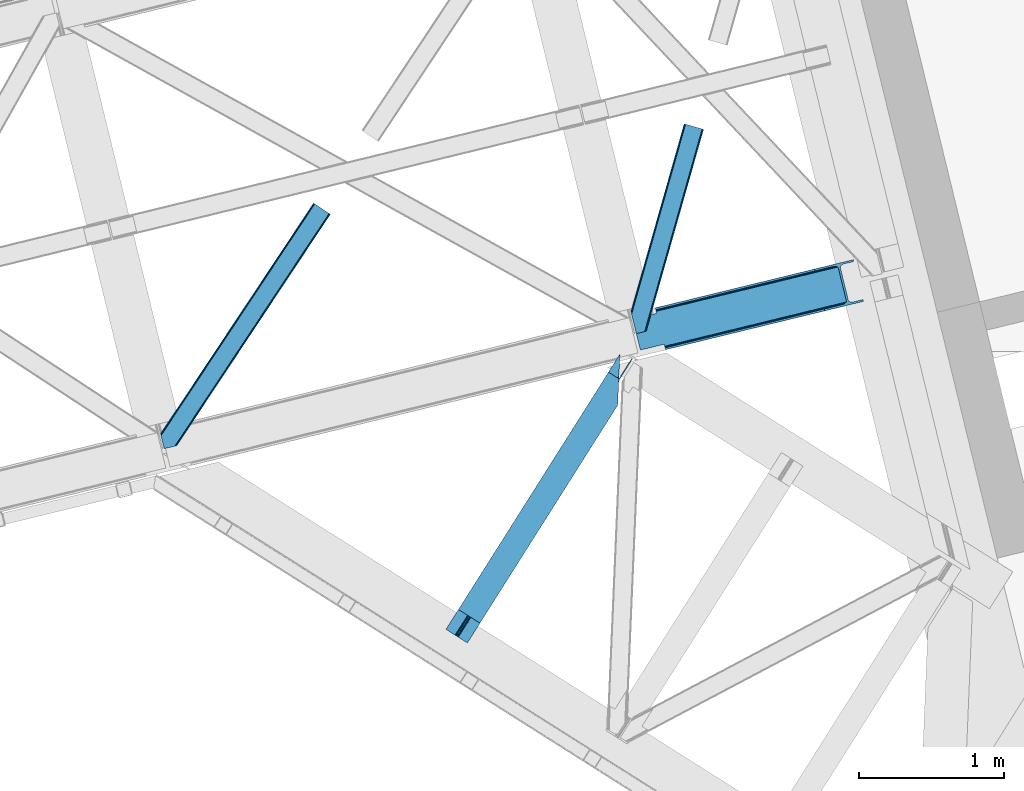
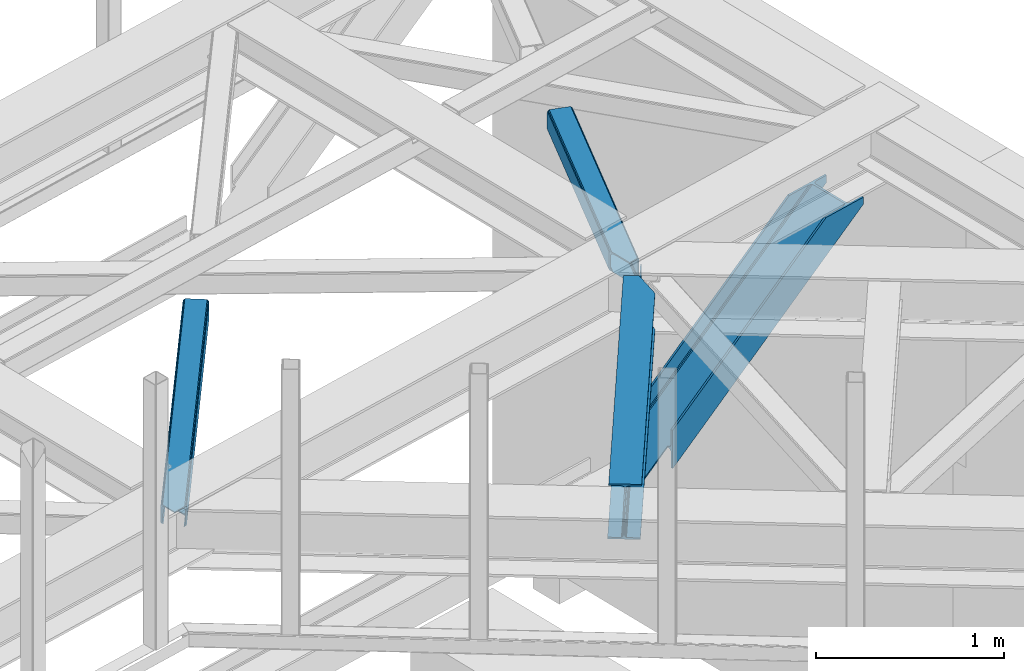
# One storey, part 58 of 66: 3 members, 1 beam.
"""IFC4 building model written with IfcOpenShell, lengths in millimetres."""

import ifcopenshell
import ifcopenshell.guid

model = None  # the IFC model being written
_history = None  # IfcOwnerHistory: only IFC2X3 demands one
_inside = {}  # id of a spatial element -> (the spatial element, [elements in it])
_under = {}  # id of a project, library or spatial element -> (it, [spatial elements below it])
_declared = {}  # id of a project -> (the project, [libraries it declares])
_typed = {}  # id of a type object -> (the type object, [elements of that type])
_made_of = {}  # id of a material, layer set ... -> (it, [elements and type objects made of it])


def new_model(schema):
    """Start an empty IFC model of exactly this schema.

    Asked for "IFC4X3", IfcOpenShell would pick the latest addendum, in which some entities
    have other attributes; the version numbers below select the first issue.
    IFC2X3 requires an IfcOwnerHistory on every rooted entity: one is made here for all.
    """
    global model, _history
    if schema == "IFC4X3":
        model = ifcopenshell.file(schema_version=(4, 3, 0, 0))
    else:
        model = ifcopenshell.file(schema=schema)
    _inside.clear()
    _under.clear()
    _declared.clear()
    _typed.clear()
    _made_of.clear()
    _history = None
    if model.schema == "IFC2X3":
        org = make("IfcOrganization", Name="unknown")
        user = make(
            "IfcPersonAndOrganization",
            ThePerson=make("IfcPerson", FamilyName="unknown"),
            TheOrganization=org,
        )
        app = make(
            "IfcApplication",
            ApplicationDeveloper=org,
            Version="unknown",
            ApplicationFullName="unknown",
            ApplicationIdentifier="unknown",
        )
        _history = make(
            "IfcOwnerHistory",
            OwningUser=user,
            OwningApplication=app,
            ChangeAction="ADDED",
            CreationDate=0,
        )
    return model


def make(cls, **values):
    """One entity of the class cls with the attributes given. An attribute that is None is left unset."""
    return model.create_entity(
        cls, **{name: value for name, value in values.items() if value is not None}
    )


def entity(cls, *values):
    """Any entity or typed value of the class cls, its attributes in the order of the schema. None: left unset."""
    e = model.create_entity(cls)
    for i, value in enumerate(values):
        if value is not None:
            e[i] = value
    return e


def rooted(cls, **values):
    """An entity with a GlobalId (a new one), such as an element, a storey or a relation."""
    return make(cls, GlobalId=ifcopenshell.guid.new(), OwnerHistory=_history, **values)


def si_unit(unit_type, name, prefix=None):
    """IfcSIUnit, for example si_unit("LENGTHUNIT", "METRE", prefix="MILLI")."""
    return make("IfcSIUnit", UnitType=unit_type, Prefix=prefix, Name=name)


def converted_unit(unit_type, name, factor, base, dimensions=None, offset=None):
    """IfcConversionBasedUnit, such as the inch: factor (a typed value) times the base unit."""
    return make(
        "IfcConversionBasedUnit"
        if offset is None
        else "IfcConversionBasedUnitWithOffset",
        ConversionOffset=offset,
        Dimensions=None
        if dimensions is None
        else entity("IfcDimensionalExponents", *dimensions),
        UnitType=unit_type,
        Name=name,
        ConversionFactor=make(
            "IfcMeasureWithUnit", ValueComponent=factor, UnitComponent=base
        ),
    )


def derived_unit(unit_type, elements):
    """IfcDerivedUnit: a product of units, each with its exponent."""
    return make(
        "IfcDerivedUnit",
        Elements=[
            make("IfcDerivedUnitElement", Unit=unit, Exponent=power)
            for unit, power in elements
        ],
        UnitType=unit_type,
    )


def assignment(units):
    """IfcUnitAssignment: the units of a project."""
    return None if units is None else make("IfcUnitAssignment", Units=units)


def point(xyz):
    """IfcCartesianPoint."""
    return None if xyz is None else make("IfcCartesianPoint", Coordinates=xyz)


def direction(xyz):
    """IfcDirection."""
    return None if xyz is None else make("IfcDirection", DirectionRatios=xyz)


def frame(location, z_axis=None, x_axis=None):
    """IfcAxis2Placement3D, a coordinate frame: its origin and axes. An axis left out is left unset."""
    return make(
        "IfcAxis2Placement3D",
        Location=point(location),
        Axis=direction(z_axis),
        RefDirection=direction(x_axis),
    )


def origin():
    """The frame at (0, 0, 0) with its axes left unset."""
    return frame((0.0, 0.0, 0.0))


def place(relative_to, where):
    """IfcLocalPlacement: puts the frame where relative to a parent placement (None: the world)."""
    return make(
        "IfcLocalPlacement", PlacementRelTo=relative_to, RelativePlacement=where
    )


def context(
    kind, dimensions, precision=None, world=None, true_north=None, identifier=None
):
    """IfcGeometricRepresentationContext, for example the 3D "Model" context."""
    return make(
        "IfcGeometricRepresentationContext",
        ContextIdentifier=identifier,
        ContextType=kind,
        CoordinateSpaceDimension=dimensions,
        Precision=precision,
        WorldCoordinateSystem=world,
        TrueNorth=true_north,
    )


def subcontext(parent, identifier, kind, view, scale=None):
    """IfcGeometricRepresentationSubContext, for example "Body" below "Model"."""
    return make(
        "IfcGeometricRepresentationSubContext",
        ContextIdentifier=identifier,
        ContextType=kind,
        ParentContext=parent,
        TargetScale=scale,
        TargetView=view,
    )


def project(units=None, contexts=None):
    """IfcProject with its units and contexts."""
    return rooted(
        "IfcProject",
        Name="project",
        RepresentationContexts=contexts,
        UnitsInContext=assignment(units),
    )


def spatial(cls, under=None, at=None, **own):
    """A site, building, storey or space (cls), placed at a placement, below another one or the project."""
    s = rooted(cls, ObjectPlacement=at, **own)
    if under is not None:
        _under.setdefault(under.id(), (under, []))[1].append(s)
    return s


def point_list(points):
    """IfcCartesianPointList2D or 3D."""
    cls = (
        "IfcCartesianPointList2D" if len(points[0]) == 2 else "IfcCartesianPointList3D"
    )
    return make(cls, CoordList=points)


def triangles(points, corners, closed=None, point_numbers=None):
    """IfcTriangulatedFaceSet: each triangle names its three corners, points numbered from 1."""
    return make(
        "IfcTriangulatedFaceSet",
        Coordinates=point_list(points),
        Closed=closed,
        CoordIndex=corners,
        PnIndex=point_numbers,
    )


def polygons(points, faces, closed=None, point_numbers=None):
    """IfcPolygonalFaceSet: a face is its outer loop, then its inner loops; points numbered from 1."""
    made = []
    for loops in faces:
        if len(loops) == 1:
            made.append(make("IfcIndexedPolygonalFace", CoordIndex=loops[0]))
        else:
            made.append(
                make(
                    "IfcIndexedPolygonalFaceWithVoids",
                    CoordIndex=loops[0],
                    InnerCoordIndices=loops[1:],
                )
            )
    return make(
        "IfcPolygonalFaceSet",
        Coordinates=point_list(points),
        Closed=closed,
        Faces=made,
        PnIndex=point_numbers,
    )


def shape(context_of_items, identifier, shape_type, items):
    """IfcShapeRepresentation: the items that make up one representation, for example the "Body"."""
    return make(
        "IfcShapeRepresentation",
        ContextOfItems=context_of_items,
        RepresentationIdentifier=identifier,
        RepresentationType=shape_type,
        Items=items,
    )


def made_of(thing, what):
    """Note that an element or type object is made of a material, layer set ...; save() writes the relation."""
    if what is not None:
        _made_of.setdefault(what.id(), (what, []))[1].append(thing)
    return thing


def type_object(cls, material=None, **own):
    """A type object (cls), such as IfcWallType, which elements share."""
    return made_of(rooted(cls, **own), material)


def element(
    cls,
    number,
    at=None,
    inside=None,
    cuts=None,
    type_object=None,
    material=None,
    context=None,
    identifier="Body",
    shape_type=None,
    held_by="IfcProductDefinitionShape",
    body=None,
    shapes=None,
    **own,
):
    """One element of the class cls, such as IfcWall. Its Tag is "e" and its number.

    at: its placement. inside: the storey or other place that contains it. cuts: it is an
    opening in that element (IfcRelVoidsElement). A single representation is given by context,
    identifier, shape_type and body (its items); several are given by shapes. held_by: the class
    of the entity that holds the representations. save() writes the other relations.
    """
    e = rooted(cls, Tag="e%d" % number, ObjectPlacement=at, **own)
    if body is not None:
        shapes = [shape(context, identifier, shape_type, body)]
    if shapes is not None:
        e.Representation = make(held_by, Representations=shapes)
    if inside is not None:
        _inside.setdefault(inside.id(), (inside, []))[1].append(e)
    if cuts is not None:
        rooted(
            "IfcRelVoidsElement", RelatingBuildingElement=cuts, RelatedOpeningElement=e
        )
    if type_object is not None:
        _typed.setdefault(type_object.id(), (type_object, []))[1].append(e)
    return made_of(e, material)


def aggregate(whole, parts):
    """IfcRelAggregates: a whole, such as a stair, and the parts it consists of."""
    return rooted("IfcRelAggregates", RelatingObject=whole, RelatedObjects=parts)


def save(model, path):
    """Write the relations noted so far, then the file.

    IfcRelAggregates (storeys below a building ...), IfcRelContainedInSpatialStructure (elements
    in a storey), IfcRelDefinesByType, IfcRelAssociatesMaterial and IfcRelDeclares: one each for
    every whole, place, type object, material and project.
    """
    for whole, parts in _under.values():
        aggregate(whole, parts)
    for where, things in _inside.values():
        rooted(
            "IfcRelContainedInSpatialStructure",
            RelatedElements=things,
            RelatingStructure=where,
        )
    for kind, things in _typed.values():
        rooted("IfcRelDefinesByType", RelatedObjects=things, RelatingType=kind)
    for what, things in _made_of.values():
        rooted("IfcRelAssociatesMaterial", RelatedObjects=things, RelatingMaterial=what)
    for by, libraries in _declared.values():
        rooted("IfcRelDeclares", RelatingContext=by, RelatedDefinitions=libraries)
    model.write(path)


model = new_model("IFC4")

# Units and contexts
model_context = context("Model", 3, precision=0.01, world=origin(), true_north=direction((6.12303176911189e-17, 1.0)))
plan_context = context("Plan", 3, precision=0.01, world=origin(), true_north=direction((6.12303176911189e-17, 1.0)))
body_context = subcontext(model_context, "Body", "Model", "MODEL_VIEW")
ifc_project = project(units=[si_unit("LENGTHUNIT", "METRE", prefix="MILLI"), si_unit("AREAUNIT", "SQUARE_METRE"), si_unit("VOLUMEUNIT", "CUBIC_METRE"), converted_unit("PLANEANGLEUNIT", "DEGREE", entity("IfcRatioMeasure", 0.0174532925199433), si_unit("PLANEANGLEUNIT", "RADIAN"), dimensions=[0, 0, 0, 0, 0, 0, 0]), si_unit("MASSUNIT", "GRAM", prefix="KILO"), derived_unit("MASSDENSITYUNIT", [(si_unit("MASSUNIT", "GRAM", prefix="KILO"), 1), (si_unit("LENGTHUNIT", "METRE"), -3)]), derived_unit("MOMENTOFINERTIAUNIT", [(si_unit("LENGTHUNIT", "METRE"), 4)]), si_unit("TIMEUNIT", "SECOND"), si_unit("FREQUENCYUNIT", "HERTZ"), si_unit("THERMODYNAMICTEMPERATUREUNIT", "DEGREE_CELSIUS"), derived_unit("THERMALTRANSMITTANCEUNIT", [(si_unit("MASSUNIT", "GRAM", prefix="KILO"), 1), (si_unit("THERMODYNAMICTEMPERATUREUNIT", "KELVIN"), -1), (si_unit("TIMEUNIT", "SECOND"), -3)]), derived_unit("VOLUMETRICFLOWRATEUNIT", [(si_unit("LENGTHUNIT", "METRE"), 3), (si_unit("TIMEUNIT", "SECOND"), -1)]), derived_unit("MASSFLOWRATEUNIT", [(si_unit("MASSUNIT", "GRAM", prefix="KILO"), 1), (si_unit("TIMEUNIT", "SECOND"), -1)]), derived_unit("ROTATIONALFREQUENCYUNIT", [(si_unit("TIMEUNIT", "SECOND"), -1)]), si_unit("ELECTRICCURRENTUNIT", "AMPERE"), si_unit("ELECTRICVOLTAGEUNIT", "VOLT"), si_unit("POWERUNIT", "WATT"), si_unit("FORCEUNIT", "NEWTON", prefix="KILO"), si_unit("ILLUMINANCEUNIT", "LUX"), si_unit("LUMINOUSFLUXUNIT", "LUMEN"), si_unit("LUMINOUSINTENSITYUNIT", "CANDELA"), derived_unit("USERDEFINED", [(si_unit("MASSUNIT", "GRAM", prefix="KILO"), -1), (si_unit("LENGTHUNIT", "METRE"), -2), (si_unit("TIMEUNIT", "SECOND"), 3), (si_unit("LUMINOUSFLUXUNIT", "LUMEN"), 1)]), derived_unit("LINEARVELOCITYUNIT", [(si_unit("LENGTHUNIT", "METRE"), 1), (si_unit("TIMEUNIT", "SECOND"), -1)]), si_unit("PRESSUREUNIT", "PASCAL"), derived_unit("USERDEFINED", [(si_unit("LENGTHUNIT", "METRE"), -2), (si_unit("MASSUNIT", "GRAM", prefix="KILO"), 1), (si_unit("TIMEUNIT", "SECOND"), -2)]), derived_unit("LINEARFORCEUNIT", [(si_unit("MASSUNIT", "GRAM", prefix="KILO"), 1), (si_unit("LENGTHUNIT", "METRE"), 1), (si_unit("TIMEUNIT", "SECOND"), -2), (si_unit("LENGTHUNIT", "METRE"), -1)]), derived_unit("PLANARFORCEUNIT", [(si_unit("MASSUNIT", "GRAM", prefix="KILO"), 1), (si_unit("LENGTHUNIT", "METRE"), 1), (si_unit("TIMEUNIT", "SECOND"), -2), (si_unit("LENGTHUNIT", "METRE"), -2)])], contexts=[model_context, plan_context])

# Site, building, storey
site_placement = place(None, origin())
site = spatial("IfcSite", under=ifc_project, at=site_placement, CompositionType="ELEMENT")
building_placement = place(site_placement, origin())
building = spatial("IfcBuilding", under=site, at=building_placement, CompositionType="ELEMENT")
storey_placement = place(building_placement, frame((0.0, 0.0, 19800.0)))
storey = spatial("IfcBuildingStorey", under=building, at=storey_placement, Name="06", CompositionType="ELEMENT", Elevation=19800.0)

# Member
member_type_1 = type_object("IfcMemberType", PredefinedType="BRACE")
member_1_placement = place(storey_placement, frame((-2187.22, 16968.36, 2617.6)))
element("IfcMember", 1, at=member_1_placement, inside=storey, type_object=member_type_1, ObjectType="Steel Vertical Brace", PredefinedType="BRACE", context=body_context, shape_type="Tessellation", body=[
    polygons([(1585.2294851225, 334.661161692477, 1042.42673521894), (1582.15074591362, 347.291338448318, 1042.42673521894), (1582.15074591362, 347.291338448318, 1088.40408877919), (1585.2294851225, 334.661161692477, 1088.40408877919), (225.056603724453, 3.10463150600978, 5.98026597646167), (221.977864515578, 15.7348082618462, 5.98026597646167), (221.977864515577, 15.7348082618462, 102.718017134371), (1515.53571242156, 331.05321926145, 1088.40408877919), (225.056603724452, 3.10463150600761, 254.823355771723), (1319.00013205867, 269.76494023208, 1088.40408877919), (217.714994841749, 33.2227453083898, 135.689726532239), (216.294038283798, 39.0520576572405, 135.689726532152), (216.294038283802, 39.0520576572405, 125.113895215846), (217.714994841748, 33.2227453083941, 125.113895215941), (219.346324440217, 26.5304015345462, 123.409110506461), (220.729298895395, 20.8569064339283, 118.554294396374), (221.653372883131, 17.0659982053532, 111.288548629352), (221.977864515572, 15.7348082618462, 254.823355771723), (221.977864515573, 15.7348082618462, 158.085604613814), (221.653372883133, 17.0659982053446, 149.515073118633), (220.729298895395, 20.856906433924, 142.249327351612), (219.346324440223, 26.5304015345462, 137.394511241533), (1451.82949340716, 592.400722901503, 1088.40408877919), (1518.44452689923, 608.638842088371, 1088.40408877919), (1515.36578769035, 621.269018844214, 1088.40408877919), (1249.13643462652, 556.372797383815, 1088.40408877919), (1252.21517383539, 543.742620627976, 1088.40408877919), (1379.16824824607, 574.688775652657, 1088.40408877919), (1390.74021368898, 576.099276446501, 1088.40408877919), (1401.19943555815, 574.632661393906, 1088.40408877918), (1408.95359213711, 570.512209341736, 1088.40408877919), (1412.8221833783, 564.365221762941, 1088.40408877919), (1468.00266304505, 337.993592215981, 1088.40408877919), (1467.39673100087, 330.755892246851, 1088.40408877919), (1462.40852333225, 323.529354097781, 1088.40408877919), (1453.79744943855, 317.414152693241, 1088.40408877919), (1442.87446726047, 313.341272012599, 1088.40408877919), (1315.92139284979, 282.395116987918, 1088.40408877918), (1503.96374697866, 329.64271846761, 1088.40408877919), (1493.50452510946, 331.109333520199, 1088.40408877918), (1485.7503685305, 335.229785572367, 1088.40408877918), (1481.8817772893, 341.376773151153, 1088.40408877919), (1426.70129762255, 567.748402698115, 1088.40408877919), (1427.30722966674, 574.986102667243, 1088.40408877919), (1432.29543733536, 582.212640816317, 1088.40408877919), (1440.90651122909, 588.327842220875, 1088.40408877919), (3.24860138789518e-12, 212.769900732995, 1.8192167772213e-10), (163.220745767809, 252.556684355379, 124.373576309325), (163.955471732924, 253.765062506503, 125.113895215868), (162.534515175014, 259.594374855358, 125.113895215928), (215.085660132705, 39.7867836223989, 124.373576309312), (51.8649143648549, 4.33146851719357e-12, 6.49720277579036e-11), (162.534515175012, 259.594374855358, 135.689726532226), (163.95547173292, 253.765062506501, 135.68972653217), (163.220745767806, 252.556684355379, 134.949407625623), (2.8966695708732e-11, 212.769900732999, 10.5758313165188), (51.8649143648817, 1.08286712929839e-11, 10.5758313164365), (215.085660132696, 39.7867836223968, 134.949407625615), (160.903185576499, 266.286718629312, 137.394511241728), (159.520211121322, 271.960213729928, 142.249327351807), (158.596137133586, 275.751121958501, 149.515073118828), (158.271645501173, 277.082311901899, 158.085604613814), (158.271645501172, 277.082311901899, 254.823355771723), (155.192906292298, 289.712488657742, 254.823355771723), (155.192906292296, 289.712488657742, 5.98026597646167), (158.271645501172, 277.082311901899, 5.98026597646167), (158.271645501173, 277.082311901904, 102.718017134371), (158.59613713359, 275.751121958499, 111.28854862956), (159.520211121322, 271.960213729926, 118.554294396582), (160.903185576492, 266.28671862931, 123.409110506656), (1518.44452689923, 608.638842088371, 1042.42673521895), (1515.36578769035, 621.269018844214, 1042.42673521894)], [[[1, 2, 3, 4]], [[5, 6, 2, 1]], [[6, 7, 8, 3, 2]], [[9, 5, 1, 4, 10]], [[11, 12, 13, 14, 15, 16, 17, 7, 6, 5, 9, 18, 19, 20, 21, 22]], [[23, 24, 25, 26, 27, 28, 29, 30, 31, 32, 33, 34, 35, 36, 37, 38, 10, 4, 3, 8, 39, 40, 41, 42, 43, 44, 45, 46]], [[42, 41, 15, 14]], [[41, 40, 16, 15]], [[40, 39, 17, 16]], [[39, 8, 7, 17]], [[18, 9, 10, 38]], [[19, 18, 38, 37]], [[37, 36, 20, 19]], [[36, 35, 21, 20]], [[35, 34, 22, 21]], [[34, 33, 11, 22]], [[47, 48, 49, 50, 43, 42, 14, 13, 51, 52]], [[53, 54, 55, 56, 57, 58, 12, 11, 33, 32]], [[58, 57, 52, 51]], [[57, 56, 47, 52]], [[56, 55, 48, 47]], [[54, 53, 59, 60, 61, 62, 63, 64, 65, 66, 67, 68, 69, 70, 50, 49]], [[23, 46, 68, 67]], [[46, 45, 69, 68]], [[45, 44, 70, 69]], [[44, 43, 50, 70]], [[67, 66, 71, 24, 23]], [[72, 25, 24, 71]], [[66, 65, 72, 71]], [[65, 64, 26, 25, 72]], [[32, 31, 59, 53]], [[31, 30, 60, 59]], [[30, 29, 61, 60]], [[29, 28, 62, 61]], [[63, 62, 28, 27]], [[64, 63, 27, 26]]], closed=False),
])

# Beam
beam_type = type_object("IfcBeamType", PredefinedType="BEAM")
beam_placement = place(storey_placement, frame((-3471.98, 14954.96, 3864.0)))
element("IfcBeam", 2, at=beam_placement, inside=storey, type_object=beam_type, ObjectType="Steel Beam", PredefinedType="BEAM", context=body_context, shape_type="Tessellation", body=[
    triangles([(1188.72613334656, 1816.41354675293, 230.999853515623), (1188.08329467773, 1793.75679016113, 228.313970947263), (1188.92815589905, 1796.73218994141, 227.025677490234), (1187.41618423462, 1786.02702941895, 230.999853515623), (1190.21528663635, 1815.46941833496, 227.193109130858), (1191.30315628052, 1805.13516540527, 223.384039306638), (1194.96863021851, 1812.46611328125, 221.005114746094), (1191.70894546509, 1814.52645263672, 223.384039306638), (1191.71897392273, 1805.96185913086, 223.116613769529), (163.219397735596, 181.395904541016, 217.00070800781), (1194.53856925964, 1812.73818969727, 217.00070800781), (164.249276733398, 180.744781494141, 223.123590087889), (167.180783843994, 178.891406250001, 228.313970947263), (1187.27709388733, 1782.76792602539, 231.783526611329), (1186.75067253113, 1770.47332763672, 232.99973144531), (171.567144012451, 176.117156982422, 231.783526611329), (176.744734954834, 172.846426391601, 232.99973144531), (1180.87254295349, 1633.92584838867, 232.99973144531), (234.219715118408, 136.50910949707, 232.99973144531), (1188.72613334656, 1816.41354675293, 244.001385498046), (1180.87254295349, 1633.92584838867, 244.001385498046), (234.219715118408, 136.50910949707, 244.001385498046), (1117.61957244873, 1861.36429138184, 244.001385498046), (86.3005462646483, 230.022006225587, 244.001385498046), (1117.61957244873, 1861.36429138184, 232.99973144531), (86.3005462646483, 230.022006225587, 232.99973144531), (1175.09905815125, 1825.02813720703, 232.99973144531), (143.779886627197, 193.685852050781, 232.99973144531), (1187.59422569275, 1817.12978210449, 223.123590087889), (1188.62410469055, 1816.47865905762, 217.00070800781), (157.300572967529, 185.135211181641, 217.00070800781), (156.270693969726, 185.786334228516, 223.123590087889), (1184.66271858215, 1818.98315734863, 228.313970947263), (153.339186859131, 187.639709472656, 228.313970947263), (1180.27214355469, 1821.75624389649, 231.783526611329), (148.953117370605, 190.413958740235, 231.783526611329), (1188.62410469055, 1816.47865905762, 204.001501464842), (1194.53856925964, 1812.73818969727, 204.001501464842), (163.219397735596, 181.395904541016, 204.001501464842), (157.300572967529, 185.135211181641, 204.001501464842), (1284.44601745605, 1954.95276489258, 202.999237060547), (1278.52704734802, 1958.6920715332, 202.999237060547), (1195.07443771362, 1813.58348693848, 202.999237060547), (1189.15546760559, 1817.32395629883, 202.999237060547), (1284.44601745605, 1954.95276489258, 119.99965209961), (1278.52704734802, 1958.6920715332, 119.99965209961), (162.88715057373, 180.872680664063, 203.057373046875), (156.76921005249, 184.291076660156, 202.999237060547), (76.9188514709472, 44.8867950439453, 202.999237060547), (71.0000267028809, 48.626101684571, 202.999237060547), (1200.5501209259, 1835.34494934082, 119.99965209961), (1199.94579734802, 1821.28883056641, 119.99965209961), (1196.02728652954, 1828.19306030274, 119.162493896485), (1195.42281761169, 1814.13694152832, 119.162493896485), (1192.19612503052, 1822.13180236816, 116.778918457032), (1191.59180145264, 1808.07568359375, 116.778918457032), (1189.63639755249, 1818.08088684082, 113.209368896485), (1189.03192863464, 1804.02476806641, 113.209368896485), (1188.73383636475, 1816.65771789551, 109.000323486329), (1188.12951278687, 1802.6015991211, 109.000323486329), (1188.95184631348, 1817.00072021484, 203.075976562501), (1188.73383636475, 1816.65771789551, 27.0006774902322), (71.0000267028809, 48.626101684571, 27.0006774902322), (1189.59076080322, 1836.49139099121, 12.2178588867173), (1190.11718215942, 1848.78598937988, 10.9993286132813), (57.4793403625486, 57.1779052734382, 10.9993286132813), (62.6525711059571, 53.9048492431648, 12.2178588867173), (1189.13977088928, 1826.06760864258, 15.6874145507791), (67.0432914733888, 51.1317626953132, 15.6874145507791), (1188.84124259949, 1819.10291748047, 20.877795410157), (69.9747985839845, 49.2783874511715, 20.877795410157), (1195.99080619812, 1985.3323059082, 10.9993286132813), (0.0, 93.5140594482418, 10.9993286132813), (1195.99080619812, 1985.3323059082, 0.0), (0.0, 93.5140594482418, 0.0), (1180.87254295349, 1633.92584838867, 0.0), (147.91916885376, 0.0, 0.0), (85.2665977478027, 39.6080474853516, 12.2178588867173), (80.8802375793457, 42.3822967529304, 15.6874145507791), (76.9188514709472, 44.8867950439453, 27.0006774902322), (77.94873046875, 44.2356719970703, 20.877795410157), (90.4441886901855, 36.3373168945309, 10.9993286132813), (147.91916885376, 0.0, 10.9993286132813), (1187.27709388733, 1782.76792602539, 12.2178588867173), (1186.75067253113, 1770.47332763672, 10.9993286132813), (1188.02661209106, 1800.15639953613, 20.877795410157), (1187.7279384613, 1793.19170837402, 15.6874145507791), (1188.12951278687, 1802.6015991211, 27.0006774902322), (1180.87254295349, 1633.92584838867, 10.9993286132813)], [[1, 2, 3], [1, 4, 2], [5, 3, 6], [7, 8, 9], [6, 9, 8], [6, 8, 5], [3, 5, 1], [10, 11, 9], [11, 7, 9], [12, 9, 6], [6, 13, 12], [6, 3, 13], [2, 13, 3], [13, 4, 14], [13, 2, 4], [14, 15, 16], [17, 16, 15], [14, 16, 13], [9, 12, 10], [15, 18, 17], [19, 17, 18], [20, 14, 4], [14, 20, 15], [4, 1, 20], [21, 15, 20], [21, 18, 15], [18, 21, 22], [22, 19, 18], [21, 23, 24], [23, 21, 20], [24, 22, 21], [23, 25, 24], [26, 24, 25], [25, 27, 28], [28, 26, 25], [29, 30, 31], [31, 32, 29], [33, 29, 32], [32, 34, 33], [35, 33, 36], [34, 36, 33], [27, 35, 36], [36, 28, 27], [1, 35, 20], [8, 7, 11], [30, 11, 37], [37, 11, 38], [8, 29, 5], [11, 30, 8], [5, 33, 1], [27, 20, 35], [33, 5, 29], [30, 29, 8], [33, 35, 1], [27, 23, 20], [23, 27, 25], [13, 16, 36], [17, 22, 24], [19, 22, 17], [16, 17, 28], [10, 12, 32], [12, 13, 32], [39, 10, 40], [34, 13, 36], [24, 28, 17], [28, 36, 16], [24, 26, 28], [32, 31, 10], [31, 40, 10], [34, 32, 13], [41, 42, 43], [44, 43, 42], [41, 45, 42], [46, 42, 45], [47, 48, 49], [50, 49, 48], [46, 45, 51], [52, 51, 45], [51, 52, 53], [54, 53, 52], [53, 54, 55], [56, 55, 54], [57, 55, 56], [56, 58, 57], [59, 57, 58], [58, 60, 59], [57, 37, 61], [57, 61, 55], [53, 55, 61], [42, 46, 51], [51, 61, 42], [61, 51, 53], [62, 48, 59], [59, 48, 31], [63, 48, 62], [63, 50, 48], [31, 37, 59], [59, 37, 57], [31, 30, 37], [64, 65, 66], [66, 67, 64], [68, 64, 67], [67, 69, 68], [70, 68, 69], [69, 71, 70], [62, 70, 71], [71, 63, 62], [65, 72, 73], [73, 66, 65], [72, 74, 75], [75, 73, 72], [74, 76, 75], [77, 75, 76], [78, 79, 67], [80, 71, 81], [79, 81, 69], [80, 49, 63], [82, 75, 77], [77, 83, 82], [82, 78, 66], [67, 79, 69], [71, 80, 63], [50, 63, 49], [71, 69, 81], [75, 82, 66], [67, 66, 78], [73, 75, 66], [68, 64, 84], [65, 74, 76], [72, 74, 65], [64, 65, 85], [62, 70, 86], [70, 68, 87], [59, 62, 88], [87, 68, 84], [76, 85, 65], [85, 84, 64], [76, 89, 85], [86, 88, 62], [88, 60, 59], [87, 86, 70], [86, 88, 80], [80, 81, 86], [87, 86, 81], [81, 79, 87], [84, 87, 79], [79, 78, 84], [85, 84, 78], [78, 82, 85], [89, 85, 82], [82, 83, 89], [76, 89, 77], [83, 77, 89]]),
])

# Members
member_type_2 = type_object("IfcMemberType", PredefinedType="BRACE")
member_2_placement = place(storey_placement, frame((-5433.35, 16290.3, 3823.02)))
element("IfcMember", 3, at=member_2_placement, inside=storey, type_object=member_type_2, ObjectType="Steel Horizontal Brace", PredefinedType="BRACE", context=body_context, shape_type="Tessellation", body=[
    triangles([(1167.55605926514, 1611.29350891113, 17.4989318847656), (1167.55605926514, 1611.29350891113, 122.499499511716), (112.764628601074, 21.275445556641, 17.4989318847656), (112.764628601074, 21.275445556641, 122.499499511716), (1166.44769668579, 1612.03067321777, 129.196765136716), (110.858349609375, 20.810357666016, 129.196765136716), (1163.28451766968, 1614.12705688477, 134.873162841795), (105.426704406738, 19.486019897462, 134.873162841795), (1158.55573654175, 1617.26640014649, 138.668280029295), (97.3022003173828, 17.5059082031257, 138.668280029295), (1152.97613525391, 1620.96849975586, 139.998431396481), (87.713832092285, 15.1688415527351, 139.998431396481), (5.64326019287091, 81.3950317382823, 139.998431396481), (1065.47537155151, 1679.01263122559, 139.998431396481), (25.4839096069336, 0.0, 139.998431396481), (1059.89577026367, 1682.71473083496, 138.668280029295), (3.48350830078107, 90.2537933349613, 138.668280029295), (1055.16698913574, 1685.85407409668, 134.873162841795), (1.65280609130878, 97.7649627685551, 134.873162841795), (1052.00381011963, 1687.95045776367, 129.196765136716), (0.42962493896448, 102.7832611084, 129.196765136716), (1050.89573822022, 1688.68762207031, 122.499499511716), (0.0, 104.544781494142, 122.499499511716), (1050.89573822022, 1688.68762207031, 17.4989318847656), (0.0, 104.544781494142, 17.4989318847656), (1166.44769668579, 1612.03067321777, 10.8016662597656), (1163.28451766968, 1614.12705688477, 5.12526855468604), (159.822802734375, 95.9557708740231, 9.25757446288844), (160.257078552246, 97.3742889404293, 8.49948120117188), (159.407711791992, 100.858959960939, 5.12526855468604), (110.469419860839, 20.7150146484382, 10.8691040039048), (109.995030212403, 20.5999053955074, 9.49942016601563), (1152.97613525391, 1620.96849975586, 0.0), (1158.55573654175, 1617.26640014649, 1.33247680663771), (155.417839050293, 117.227728271484, 0.0), (157.577009582519, 108.368966674805, 1.33247680663771), (1065.47537155151, 1679.01263122559, 0.0), (121.558859252929, 256.129714965822, 0.0), (155.314356994629, 113.429122924807, 9.49942016601563), (90.5967956542972, 15.8711242675781, 9.49942016601563), (155.425978088379, 114.267443847655, 9.2947814941399), (155.539343261718, 115.1185546875, 9.08781738280959), (160.118714904786, 96.9219909667972, 8.74132690429542), (155.650964355469, 115.956875610353, 8.8831787109375), (155.446325683593, 117.1102935791, 8.49948120117188), (1152.72004623413, 1621.13593139648, 8.33204956054396), (1147.14073562622, 1624.83803100586, 6.99957275390625), (153.160418701172, 126.488790893554, 6.99957275390625), (1157.45347824097, 1617.99775085449, 12.1248413085923), (95.4092926025387, 17.0443084716808, 12.1248413085923), (1161.72501983643, 1615.16420288086, 24.4985046386719), (1160.61200637817, 1615.90020446777, 17.8035644531228), (102.742565917969, 18.8325714111324, 24.4985046386719), (100.835705566406, 18.3674835205074, 17.8035644531228), (1161.72501983643, 1615.16420288086, 115.49992675781), (102.742565917969, 18.8325714111324, 115.49992675781), (100.835705566406, 18.3674835205074, 122.19719238281), (87.2801376342777, 15.0630340576172, 131.666381835938), (77.6917694091799, 12.7259674072266, 132.998858642575), (25.4839096069336, 0.0, 132.998858642575), (95.4092926025387, 17.0443084716808, 127.873590087889), (1147.14073562622, 1624.83803100586, 132.998858642575), (1152.72004623413, 1621.13593139648, 131.666381835938), (1157.45347824097, 1617.99775085449, 127.873590087889), (1160.61200637817, 1615.90020446777, 122.19719238281), (7.90068054199219, 72.1351318359375, 132.998858642575), (1071.3107711792, 1675.14309997558, 132.998858642575), (1056.72648696899, 1684.81692810058, 115.49992675781), (1057.83950042725, 1684.0820892334, 122.19719238281), (2.25742034912128, 95.2848815917987, 115.49992675781), (2.68704528808576, 93.5233612060547, 122.19719238281), (1060.99802856445, 1681.98338012695, 127.873590087889), (3.91022644043005, 88.505062866212, 127.873590087889), (1065.73146057129, 1678.84636230469, 131.666381835938), (5.74092864990234, 80.9938934326183, 131.666381835938), (1060.99802856445, 1681.98338012695, 12.1248413085923), (1059.89577026367, 1682.71473083496, 1.33247680663771), (1055.16698913574, 1685.85407409668, 5.12526855468604), (1071.3107711792, 1675.14309997558, 6.99957275390625), (1065.73146057129, 1678.84636230469, 8.33204956054396), (1056.72648696899, 1684.81692810058, 24.4985046386719), (1052.00381011963, 1687.95045776367, 10.8016662597656), (1057.83950042725, 1684.0820892334, 17.8035644531228), (2.25742034912128, 95.2848815917987, 24.4985046386719), (123.816279602051, 246.869815063475, 6.99957275390625), (2.88121948242224, 92.7245727539066, 16.4989929199219), (2.77483062744159, 93.1629180908203, 17.868676757811), (0.0093017578128638, 104.50757446289, 16.4989929199219), (119.399688720703, 264.988476562501, 1.33247680663771), (121.662922668457, 255.702996826172, 8.41343994140334), (117.568986511231, 272.499645996095, 5.12526855468604), (116.719619750977, 275.983154296877, 8.49948120117188), (4.73924560546857, 108.865447998049, 10.8714294433594), (115.787118530274, 275.584341430664, 9.49942016601563), (5.89266357421911, 109.927011108399, 9.49942016601563), (7.20479278564471, 93.4687133789066, 12.1248413085923), (120.157200622559, 257.658691406252, 9.49942016601563), (121.184463500977, 256.801766967774, 8.80643920898365), (10.2621643066404, 92.0013610839851, 9.49942016601563)], [[1, 2, 3], [4, 3, 2], [2, 5, 4], [6, 4, 5], [5, 7, 6], [8, 6, 7], [7, 9, 8], [10, 8, 9], [9, 11, 10], [12, 10, 11], [11, 13, 12], [11, 14, 13], [13, 15, 12], [14, 16, 17], [17, 13, 14], [16, 18, 19], [19, 17, 16], [18, 20, 21], [21, 19, 18], [20, 22, 23], [23, 21, 20], [22, 24, 23], [25, 23, 24], [26, 1, 3], [27, 28, 29], [29, 30, 27], [26, 31, 28], [28, 27, 26], [31, 32, 28], [33, 34, 35], [36, 35, 34], [34, 27, 36], [30, 36, 27], [3, 31, 26], [37, 33, 38], [35, 38, 33], [39, 28, 32], [32, 40, 39], [39, 41, 28], [41, 42, 43], [42, 44, 43], [44, 45, 29], [46, 47, 48], [49, 46, 45], [45, 44, 49], [49, 42, 41], [42, 49, 44], [41, 39, 49], [49, 39, 50], [40, 50, 39], [48, 45, 46], [51, 52, 53], [54, 53, 52], [52, 49, 54], [50, 54, 49], [55, 51, 53], [53, 56, 55], [57, 4, 6], [58, 10, 12], [15, 59, 12], [59, 15, 60], [59, 58, 12], [61, 10, 58], [61, 57, 8], [8, 10, 61], [6, 8, 57], [53, 3, 4], [50, 32, 54], [57, 56, 4], [50, 40, 32], [53, 54, 3], [56, 53, 4], [31, 3, 54], [54, 32, 31], [62, 63, 58], [58, 59, 62], [63, 64, 61], [61, 58, 63], [64, 65, 57], [57, 61, 64], [65, 55, 56], [56, 57, 65], [62, 66, 67], [66, 62, 59], [60, 66, 59], [68, 69, 70], [71, 70, 69], [69, 72, 71], [73, 71, 72], [72, 74, 73], [75, 73, 74], [74, 67, 75], [66, 75, 67], [26, 49, 52], [51, 2, 1], [26, 52, 1], [26, 27, 49], [52, 51, 1], [49, 27, 34], [47, 33, 37], [33, 46, 34], [46, 33, 47], [46, 49, 34], [5, 64, 7], [55, 2, 51], [2, 65, 5], [65, 2, 55], [5, 65, 64], [11, 62, 14], [9, 7, 64], [64, 63, 9], [63, 62, 11], [11, 9, 63], [76, 77, 78], [37, 79, 47], [37, 80, 79], [80, 37, 77], [76, 80, 77], [81, 24, 22], [82, 83, 76], [78, 82, 76], [83, 82, 24], [81, 83, 24], [16, 72, 18], [14, 62, 67], [67, 74, 14], [74, 72, 16], [16, 14, 74], [20, 18, 72], [22, 68, 81], [69, 22, 20], [22, 69, 68], [69, 20, 72], [81, 68, 84], [70, 84, 68], [47, 79, 85], [85, 48, 47], [75, 66, 13], [66, 15, 13], [66, 60, 15], [17, 75, 13], [73, 17, 19], [73, 75, 17], [86, 87, 88], [23, 70, 71], [71, 19, 21], [19, 71, 73], [21, 23, 71], [23, 84, 70], [25, 88, 87], [25, 84, 23], [84, 25, 87], [85, 38, 48], [89, 90, 91], [90, 89, 38], [91, 90, 92], [38, 85, 90], [48, 38, 35], [36, 45, 35], [45, 36, 30], [35, 45, 48], [30, 29, 45], [24, 82, 93], [93, 25, 24], [94, 93, 82], [94, 95, 93], [78, 91, 92], [92, 82, 78], [92, 94, 82], [78, 77, 91], [89, 91, 77], [77, 37, 89], [38, 89, 37], [93, 88, 25], [83, 81, 84], [83, 86, 96], [83, 87, 86], [80, 97, 98], [76, 96, 97], [97, 80, 76], [96, 99, 97], [79, 80, 90], [90, 85, 79], [96, 76, 83], [84, 87, 83], [95, 96, 93], [95, 99, 96], [96, 88, 93], [86, 88, 96], [94, 97, 95], [99, 95, 97]]),
])
member_type_3 = type_object("IfcMemberType", PredefinedType="BRACE")
member_3_placement = place(storey_placement, frame((-2200.6, 17081.3, 3823.02)))
element("IfcMember", 4, at=member_3_placement, inside=storey, type_object=member_type_3, ObjectType="Steel Horizontal Brace", PredefinedType="BRACE", context=body_context, shape_type="Tessellation", body=[
    triangles([(382.458631896973, 1437.45993347168, 139.998431396481), (376.014548492432, 1439.28889160157, 138.668280029295), (5.18718338012695, 133.445343017578, 138.668280029295), (8.40283012390137, 120.253125000003, 139.998431396481), (370.552672576904, 1440.83879699707, 134.873162841795), (2.46118698120108, 144.628381347658, 134.873162841795), (366.905947494507, 1441.87594299317, 129.196765136716), (0.639641189575286, 152.101181030273, 129.196765136716), (365.625211715698, 1442.23987426758, 122.499499511716), (0.0, 154.725439453126, 122.499499511716), (365.625211715698, 1442.23987426758, 17.4989318847656), (0.0, 154.725439453126, 17.4989318847656), (86.8012424468993, 11.9643859863281, 139.998431396481), (483.46365852356, 1408.77563781738, 139.998431396481), (37.7160118103025, 0.0, 139.998431396481), (500.297078704834, 1403.99453430176, 122.499499511716), (499.016342926025, 1404.35846557617, 129.196765136716), (106.348595809936, 16.7292114257834, 122.499499511716), (104.86191329956, 16.3664428710945, 129.196765136716), (495.369617843628, 1405.39561157227, 134.873162841795), (100.623509216308, 15.3339477539084, 134.873162841795), (489.9077419281, 1406.9466796875, 138.668280029295), (94.2839252471922, 13.7886932373076, 138.668280029295), (500.297078704834, 1403.99453430176, 17.4989318847656), (106.348595809936, 16.7292114257834, 17.4989318847656), (370.552672576904, 1440.83879699707, 5.12526855468604), (376.014548492432, 1439.28889160157, 1.33247680663771), (64.4095859527588, 341.997729492188, 1.33247680663771), (366.905947494507, 1441.87594299317, 10.8016662597656), (57.6633407592772, 340.35364379883, 5.49966430664063), (1.58013610839816, 155.411444091798, 10.8016662597656), (0.350269317626953, 153.288317871094, 12.4992370605469), (6.16328659057626, 158.997271728516, 5.49966430664063), (382.458631896973, 1437.45993347168, 0.0), (71.8924140930176, 343.822036743164, 0.0), (101.030170440674, 15.4327789306662, 5.49966430664063), (149.676183700562, 186.73860168457, 5.49966430664063), (44.5164688110349, 1.65687561035156, 5.49966430664063), (109.170516586304, 352.90869140625, 5.49966430664063), (149.709902572632, 188.722201538087, 4.99969482421875), (489.9077419281, 1406.9466796875, 1.33247680663771), (495.369617843628, 1405.39561157227, 5.12526855468604), (149.739115905762, 190.703475952148, 4.49972534179688), (149.724436569214, 189.72214050293, 4.74622192382594), (147.329379272461, 200.588919067384, 1.33247680663771), (499.016342926025, 1404.35846557617, 10.8016662597656), (104.86191329956, 16.3664428710945, 10.8016662597656), (149.690717697144, 187.719937133792, 5.25084228515334), (483.46365852356, 1408.77563781738, 0.0), (144.113877868652, 213.779974365236, 0.0), (110.142114257812, 353.145886230472, 0.0), (109.541133499145, 352.999383544924, 5.42292480468677), (110.142114257812, 353.145886230472, 4.49972534179688), (43.0614704132081, 1.30224609375, 6.99957275390625), (14.8120319366453, 117.192846679689, 6.99957275390625), (10.8560234069823, 127.785223388673, 8.33204956054396), (5.64776573181143, 131.555923461914, 12.4992370605469), (377.289616012573, 1438.92844848633, 12.1248413085923), (373.638385391235, 1439.96326904297, 17.8035644531228), (4.00077323913547, 138.312487792969, 17.8035644531228), (389.191069793701, 1435.54725952149, 6.99957275390625), (382.751637268066, 1437.37738037109, 8.33204956054396), (372.357649612427, 1440.32720031738, 24.4985046386719), (3.36113204956064, 140.936746215823, 24.4985046386719), (78.9841323852538, 10.0586883544929, 6.99957275390625), (476.731220626831, 1410.68831176758, 6.99957275390625), (372.357649612427, 1440.32720031738, 115.49992675781), (3.36113204956064, 140.936746215823, 115.49992675781), (5.82231903076172, 130.839688110354, 127.873590087889), (4.00077323913547, 138.312487792969, 122.19719238281), (8.54831542968759, 119.656649780274, 131.666381835938), (11.763962173462, 106.464431762695, 132.998858642575), (37.7160118103025, 0.0, 132.998858642575), (373.638385391235, 1439.96326904297, 122.19719238281), (377.289616012573, 1438.92844848633, 127.873590087889), (382.751637268066, 1437.37738037109, 131.666381835938), (389.191069793701, 1435.54725952149, 132.998858642575), (78.9841323852538, 10.0586883544929, 132.998858642575), (476.731220626831, 1410.68831176758, 132.998858642575), (488.632529067993, 1407.30712280274, 12.1248413085923), (492.283905029297, 1406.27113952637, 17.8035644531228), (493.564640808105, 1405.90720825196, 24.4985046386719), (483.175158691406, 1408.8593536377, 8.33204956054396), (488.632529067993, 1407.30712280274, 127.873590087889), (493.564640808105, 1405.90720825196, 115.49992675781), (492.283905029297, 1406.27113952637, 122.19719238281), (483.175158691406, 1408.8593536377, 131.666381835938), (86.4623096466062, 11.8818328857451, 131.666381835938), (92.8063991546628, 13.4282501220732, 127.873590087889), (97.0402976989744, 14.4607452392593, 122.19719238281), (98.5314857482908, 14.8235137939482, 115.49992675781), (86.4623096466062, 11.8818328857451, 8.33204956054396), (97.0402976989744, 14.4607452392593, 17.8035644531228), (92.8063991546628, 13.4282501220732, 12.1248413085923), (98.5314857482908, 14.8235137939482, 24.4985046386719)], [[1, 2, 3], [3, 4, 1], [2, 5, 6], [6, 3, 2], [5, 7, 8], [8, 6, 5], [7, 9, 10], [10, 8, 7], [9, 11, 12], [12, 10, 9], [4, 13, 14], [13, 4, 15], [14, 1, 4], [16, 17, 18], [19, 18, 17], [17, 20, 19], [21, 19, 20], [20, 22, 21], [23, 21, 22], [22, 14, 23], [13, 23, 14], [24, 16, 25], [18, 25, 16], [26, 27, 28], [29, 26, 30], [11, 29, 31], [31, 12, 11], [31, 32, 12], [29, 30, 31], [33, 31, 30], [28, 30, 26], [27, 34, 35], [35, 28, 27], [36, 33, 37], [36, 38, 33], [30, 37, 33], [39, 37, 30], [40, 41, 42], [43, 41, 44], [40, 44, 41], [43, 45, 41], [46, 47, 37], [37, 42, 46], [37, 48, 42], [47, 36, 37], [46, 24, 25], [25, 47, 46], [49, 41, 50], [45, 50, 41], [51, 35, 34], [50, 51, 49], [34, 49, 51], [35, 30, 28], [35, 51, 52], [35, 52, 30], [52, 51, 53], [48, 37, 39], [44, 40, 53], [43, 44, 53], [53, 50, 43], [50, 53, 51], [45, 43, 50], [38, 54, 55], [33, 55, 56], [55, 33, 38], [57, 31, 33], [33, 56, 57], [32, 31, 57], [58, 59, 60], [60, 57, 58], [61, 62, 56], [56, 55, 61], [62, 58, 57], [57, 56, 62], [59, 63, 64], [64, 60, 59], [55, 65, 66], [65, 55, 54], [66, 61, 55], [63, 67, 64], [68, 64, 67], [69, 6, 70], [71, 72, 4], [72, 15, 4], [72, 73, 15], [3, 71, 4], [69, 3, 6], [69, 71, 3], [10, 64, 68], [8, 70, 6], [68, 70, 10], [70, 8, 10], [12, 64, 10], [32, 57, 60], [60, 64, 12], [12, 32, 60], [67, 74, 68], [70, 68, 74], [74, 75, 70], [69, 70, 75], [75, 76, 69], [71, 69, 76], [76, 77, 71], [72, 71, 77], [78, 72, 79], [78, 73, 72], [77, 79, 72], [46, 80, 81], [82, 16, 24], [46, 81, 24], [46, 42, 80], [81, 82, 24], [80, 42, 41], [66, 49, 34], [49, 83, 41], [83, 49, 66], [83, 80, 41], [17, 84, 20], [85, 16, 82], [16, 86, 17], [86, 16, 85], [17, 86, 84], [14, 79, 1], [22, 20, 84], [84, 87, 22], [87, 79, 14], [14, 22, 87], [58, 27, 26], [34, 61, 66], [34, 62, 61], [62, 34, 27], [58, 62, 27], [63, 11, 9], [29, 59, 58], [26, 29, 58], [59, 29, 11], [63, 59, 11], [2, 75, 5], [1, 79, 77], [77, 76, 1], [76, 75, 2], [2, 1, 76], [7, 5, 75], [9, 67, 63], [74, 9, 7], [9, 74, 67], [74, 7, 75], [23, 13, 88], [15, 78, 13], [78, 15, 73], [78, 88, 13], [89, 23, 88], [89, 21, 23], [19, 89, 90], [89, 19, 21], [18, 90, 91], [90, 18, 19], [65, 36, 92], [93, 94, 47], [94, 92, 36], [65, 38, 36], [38, 65, 54], [95, 93, 25], [47, 25, 93], [18, 95, 25], [95, 18, 91], [94, 36, 47], [82, 81, 95], [93, 95, 81], [81, 80, 93], [94, 93, 80], [80, 83, 94], [92, 94, 83], [83, 66, 92], [65, 92, 66], [85, 82, 95], [95, 91, 85], [79, 87, 88], [88, 78, 79], [87, 84, 89], [89, 88, 87], [84, 86, 90], [90, 89, 84], [86, 85, 91], [91, 90, 86]]),
])

save(model, "model.ifc")
